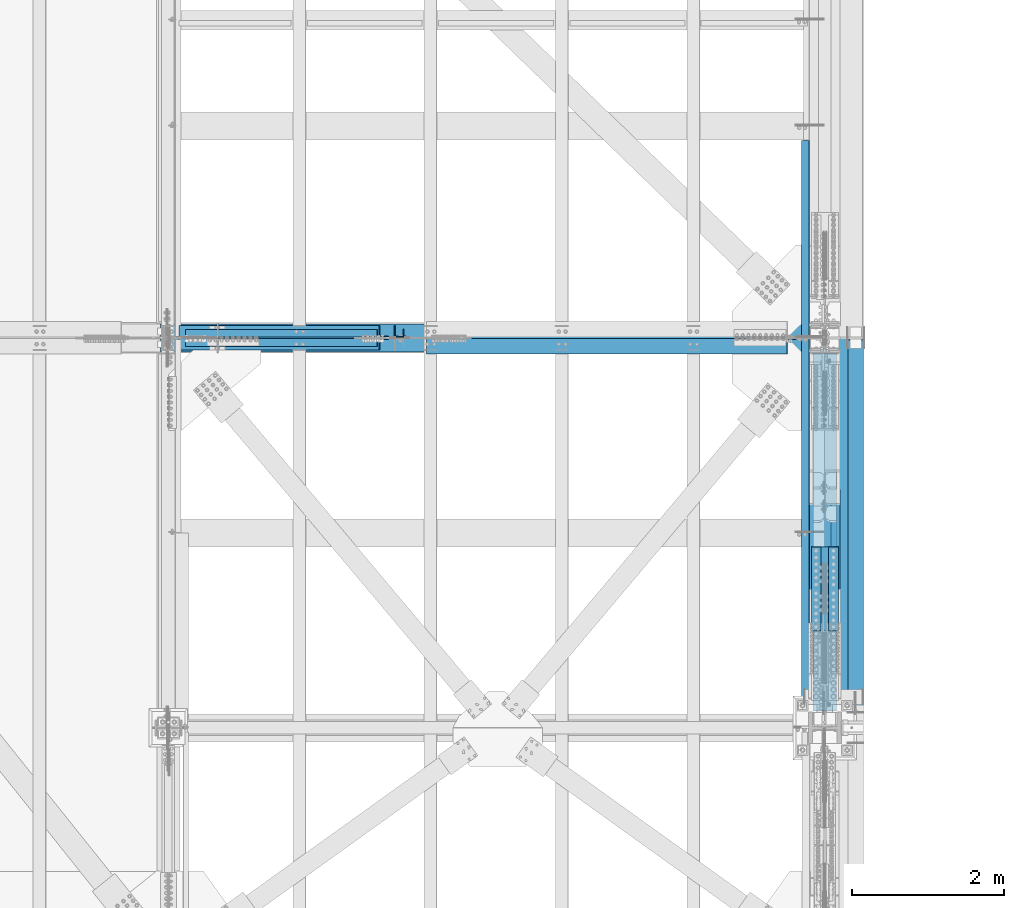
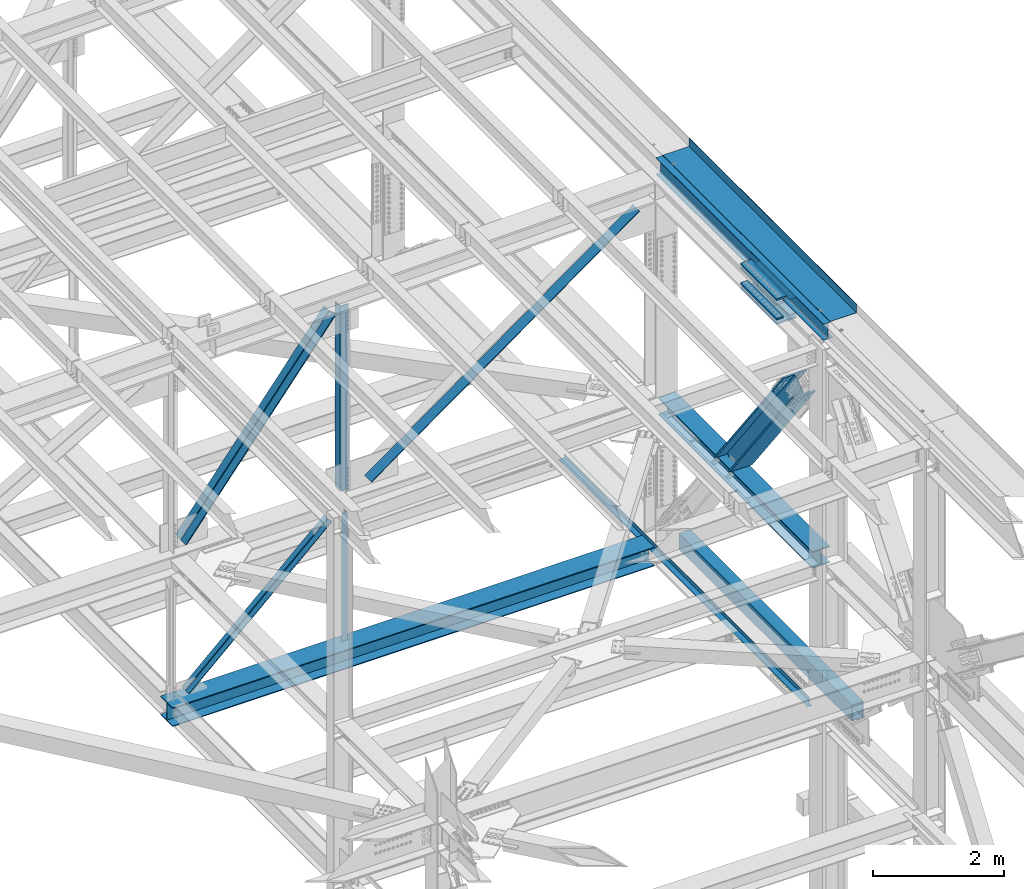
# One storey, part 1959 of 3843: 14 beams, 6 members, 14 elements without a shape of their own.
"""IFC2X3 building model written with IfcOpenShell, lengths in millimetres."""

from ifc_helpers import new_model, si_unit, frame, origin_with_axes, place, context, subcontext, project, spatial, faceted_brep, material, type_object, element, aggregate, save


model = new_model("IFC2X3")

# Units and contexts
model_context = context("Model", 3, precision=1e-05, world=origin_with_axes())
body_context = subcontext(model_context, "Body", "Model", "MODEL_VIEW")
ifc_project = project(units=[si_unit("LENGTHUNIT", "METRE", prefix="MILLI"), si_unit("AREAUNIT", "SQUARE_METRE"), si_unit("VOLUMEUNIT", "CUBIC_METRE"), si_unit("MASSUNIT", "GRAM", prefix="KILO"), si_unit("TIMEUNIT", "SECOND"), si_unit("PLANEANGLEUNIT", "RADIAN"), si_unit("SOLIDANGLEUNIT", "STERADIAN"), si_unit("THERMODYNAMICTEMPERATUREUNIT", "DEGREE_CELSIUS"), si_unit("LUMINOUSINTENSITYUNIT", "LUMEN")], contexts=[model_context])

# Site, building, storey
site_placement = place(None, origin_with_axes())
site = spatial("IfcSite", under=ifc_project, at=site_placement, CompositionType="ELEMENT")
building_placement = place(site_placement, origin_with_axes())
building = spatial("IfcBuilding", under=site, at=building_placement, Name="Undefined", CompositionType="ELEMENT")
storey_placement = place(building_placement, origin_with_axes())
storey = spatial("IfcBuildingStorey", under=building, at=storey_placement, Name="Undefined", CompositionType="ELEMENT", Elevation=0.0)

# Assembly, beam
assembly_1_placement = place(storey_placement, origin_with_axes())
assembly_1 = element("IfcElementAssembly", 1, at=assembly_1_placement, inside=storey, Name="ANGLE", AssemblyPlace="NOTDEFINED", PredefinedType="RIGID_FRAME")
ifc_material_1 = material(Name="STEEL/A572-50")
beam_type_1 = type_object("IfcBeamType", Name="L4X4X3/8", PredefinedType="NOTDEFINED")
beam_1_placement = place(assembly_1_placement, frame((80060.7999999843, 33905.825, 42267.5451161641), z_axis=(-1.0, 0.0, 0.0), x_axis=(0.0, 0.0, -1.0)))
beam_1 = element("IfcBeam", 2, at=beam_1_placement, type_object=beam_type_1, material=ifc_material_1, Name="ANGLE", ObjectType="L4X4X3/8", context=body_context, shape_type="Brep", body=[
    faceted_brep([(209.49954484457, 50.8000000000029, -50.8000000000029), (209.49954484457, 50.8000000000029, 50.8000000000029), (2609.48678539136, 50.8000000000029, 50.8000000000029), (2609.48678539136, 50.8000000000029, -50.8000000000029), (209.49954484457, 41.2750000000015, 50.8000000000029), (2609.48678539136, 41.2750000000015, 50.8000000000029), (209.49954484457, 41.2750000000015, -41.2749999999942), (2609.48678539136, 41.2750000000015, -41.2749999999942), (209.49954484457, -50.8000000000029, -41.2749999999942), (2609.48678539136, -50.8000000000029, -41.2749999999942), (209.49954484457, -50.8000000000029, -50.8000000000029), (2609.48678539136, -50.8000000000029, -50.8000000000029)], [[[0, 1, 2, 3]], [[1, 4, 5, 2]], [[4, 6, 7, 5]], [[6, 8, 9, 7]], [[8, 10, 11, 9]], [[10, 0, 3, 11]], [[5, 7, 9, 11, 3, 2]], [[10, 8, 6, 4, 1, 0]]]),
])
aggregate(assembly_1, [beam_1])

assembly_2_placement = place(storey_placement, origin_with_axes())
assembly_2 = element("IfcElementAssembly", 3, at=assembly_2_placement, inside=storey, Name="BEAM", AssemblyPlace="NOTDEFINED", PredefinedType="RIGID_FRAME")
ifc_material_2 = material(Name="STEEL/A992")
beam_type_2 = type_object("IfcBeamType", Name="W12X26", PredefinedType="NOTDEFINED")
beam_2_placement = place(assembly_2_placement, frame((85648.8000000006, 28714.7, 46612.1749999998), z_axis=(0.0, 0.0, 1.0), x_axis=(0.0, 1.0, 0.0)))
beam_2 = element("IfcBeam", 4, at=beam_2_placement, type_object=beam_type_2, material=ifc_material_2, Name="BEAM", ObjectType="W12X26", context=body_context, shape_type="Brep", body=[
    faceted_brep([(1250.95, -3.17500000000291, -146.050000000003), (1250.95, -82.5500000000029, -146.050000000003), (1250.95, -82.5500000000029, -155.574999999997), (1250.95, 82.5500000000029, -155.574999999997), (1250.95, 82.5500000000029, -146.050000000003), (1250.95, 3.17500000000291, -146.050000000003), (1250.95000000001, 3.17500000000291, -92.0749999997934), (1250.95000000001, -3.17500000000291, -92.0749999997934), (2406.65000000001, -3.17500000000291, -92.0749999997934), (2406.65000000001, 3.17500000000291, -92.0749999997934), (2406.65000000001, 3.17500000000291, -146.050000000003), (2406.65000000001, 82.5500000000029, -146.050000000003), (2406.65000000001, 82.5500000000029, -155.574999999997), (2406.65000000001, -82.5500000000029, -155.574999999997), (2406.65000000001, -82.5500000000029, -146.050000000003), (2406.65000000001, -3.17500000000291, -146.050000000003), (0.0, -82.5500000000029, 155.574999999997), (0.0, -82.5500000000029, 146.050000000003), (5130.8, -82.5500000000029, 146.050000000003), (5130.8, -82.5500000000029, 155.574999999997), (0.0, 82.5500000000029, 155.574999999997), (5130.8, 82.5500000000029, 155.574999999997), (0.0, 82.5500000000029, 146.050000000003), (5130.8, 82.5500000000029, 146.050000000003), (0.0, 3.17500000000291, 146.050000000003), (5130.8, 3.17500000000291, 146.050000000003), (0.0, -82.5500000000029, -155.574999999997), (0.0, -82.5500000000029, -146.050000000003), (0.0, -3.17500000000291, -146.050000000003), (0.0, -3.17500000000291, 146.050000000003), (0.0, 3.17500000000291, -146.050000000003), (0.0, 82.5500000000029, -146.050000000003), (0.0, 82.5500000000029, -155.574999999997), (5130.8, -3.17500000000291, 146.050000000003), (5130.8, 3.17500000000291, -146.050000000003), (5130.8, -3.17500000000291, -146.050000000003), (5130.8, -82.5500000000029, -146.050000000003), (5130.8, -82.5500000000029, -155.574999999997), (5130.8, 82.5500000000029, -155.574999999997), (5130.8, 82.5500000000029, -146.050000000003)], [[[0, 1, 2, 3, 4, 5, 6, 7]], [[8, 9, 10, 11, 12, 13, 14, 15]], [[7, 6, 9, 8]], [[16, 17, 18, 19]], [[20, 16, 19, 21]], [[22, 20, 21, 23]], [[24, 22, 23, 25]], [[26, 27, 28, 29, 17, 16, 20, 22, 24, 30, 31, 32]], [[17, 29, 33, 18]], [[34, 25, 23, 21, 19, 18, 33, 35, 36, 37, 38, 39]], [[36, 35, 15, 14]], [[37, 36, 14, 13]], [[38, 37, 13, 12]], [[39, 38, 12, 11]], [[34, 39, 11, 10]], [[5, 30, 24, 25, 34, 10, 9, 6]], [[31, 30, 5, 4]], [[32, 31, 4, 3]], [[26, 32, 3, 2]], [[27, 26, 2, 1]], [[28, 27, 1, 0]], [[35, 33, 29, 28, 0, 7, 8, 15]]]),
])

# Assembly, member
assembly_3_placement = place(storey_placement, origin_with_axes())
assembly_3 = element("IfcElementAssembly", 5, at=assembly_3_placement, inside=storey, Name="ANGLE", AssemblyPlace="NOTDEFINED", PredefinedType="RIGID_FRAME")
member_type_1 = type_object("IfcMemberType", Name="L4X4X3/8", PredefinedType="NOTDEFINED")
member_1_placement = place(assembly_3_placement, frame((80060.7999999843, 33905.825, 42267.5451161641), z_axis=(0.0, 1.0, 0.0), x_axis=(-0.733899008140415, 0.0, -0.679258600129962)))
member_1 = element("IfcMember", 6, at=member_1_placement, type_object=member_type_1, material=ifc_material_1, Name="ANGLE", ObjectType="L4X4X3/8", context=body_context, shape_type="Brep", body=[
    faceted_brep([(363.598779794396, 50.7999999975509, -50.8000000000029), (363.598779794396, 50.7999999975509, 50.8000000000029), (3797.94778411629, 50.7999999761196, 50.8000000000029), (3797.94778411629, 50.7999999761196, -50.8000000000029), (363.598779794484, 41.2749999975786, 50.8000000000029), (3797.94778411639, 41.2749999761545, 50.8000000000029), (363.598779794484, 41.2749999975786, -41.2750000000015), (3797.94778411639, 41.2749999761545, -41.2750000000015), (363.598779795444, -50.8000000021093, -41.2750000000015), (3797.94778411734, -50.8000000235443, -41.2750000000015), (363.598779795444, -50.8000000021093, -50.8000000000029), (3797.94778411734, -50.8000000235443, -50.8000000000029)], [[[0, 1, 2, 3]], [[1, 4, 5, 2]], [[4, 6, 7, 5]], [[6, 8, 9, 7]], [[8, 10, 11, 9]], [[10, 0, 3, 11]], [[5, 7, 9, 11, 3, 2]], [[10, 8, 6, 4, 1, 0]]]),
])
aggregate(assembly_3, [member_1])

assembly_4_placement = place(storey_placement, origin_with_axes())
assembly_4 = element("IfcElementAssembly", 7, at=assembly_4_placement, inside=storey, Name="ANGLE", AssemblyPlace="NOTDEFINED", PredefinedType="RIGID_FRAME")
member_2_placement = place(assembly_4_placement, frame((77012.8000000054, 33785.175, 39446.4754738793), z_axis=(0.0, -1.0, 0.0), x_axis=(0.733899008140419, 0.0, 0.679258600129958)))
member_2 = element("IfcMember", 8, at=member_2_placement, type_object=member_type_1, material=ifc_material_1, Name="ANGLE", ObjectType="L4X4X3/8", context=body_context, shape_type="Brep", body=[
    faceted_brep([(355.212209667981, 50.8000000020438, -50.8000000000029), (355.212209667981, 50.8000000020438, 50.8000000000029), (3789.56121398989, 50.8000000234751, 50.8000000000029), (3789.56121398989, 50.8000000234751, -50.8000000000029), (355.212209667894, 41.2750000020751, 50.8000000000029), (3789.5612139898, 41.2750000235028, 50.8000000000029), (355.212209667894, 41.2750000020751, -41.2750000000015), (3789.5612139898, 41.2750000235028, -41.2750000000015), (355.212209666948, -50.7999999976091, -41.2750000000015), (3789.56121398884, -50.7999999761814, -41.2750000000015), (355.212209666948, -50.7999999976091, -50.8000000000029), (3789.56121398884, -50.7999999761814, -50.8000000000029)], [[[0, 1, 2, 3]], [[1, 4, 5, 2]], [[4, 6, 7, 5]], [[6, 8, 9, 7]], [[8, 10, 11, 9]], [[10, 0, 3, 11]], [[5, 7, 9, 11, 3, 2]], [[10, 8, 6, 4, 1, 0]]]),
])
aggregate(assembly_4, [member_2])

# Assembly, beam
assembly_5_placement = place(storey_placement, origin_with_axes())
assembly_5 = element("IfcElementAssembly", 9, at=assembly_5_placement, inside=storey, Name="BEAM", AssemblyPlace="NOTDEFINED", PredefinedType="RIGID_FRAME")
ifc_material_3 = material()
beam_type_3 = type_object("IfcBeamType", Name="HSS12X8X3/8", PredefinedType="NOTDEFINED")
beam_3_placement = place(assembly_5_placement, frame((86055.2000000001, 33820.1000003927, 39477.9500003874), z_axis=(0.0, 0.0, 1.0), x_axis=(0.0, -1.0, 0.0)))
beam_3 = element("IfcBeam", 10, at=beam_3_placement, type_object=beam_type_3, material=ifc_material_3, Name="BEAM", ObjectType="HSS12X8X3/8", context=body_context, shape_type="Brep", body=[
    faceted_brep([(0.0, 92.0749999999971, -142.875), (0.0, -92.0749999999971, -142.875), (5302.2500003815, -92.0749999999971, -142.875), (5302.2500003815, 92.0749999999971, -142.875), (0.0, -92.0749999999971, 142.875), (5302.2500003815, -92.0749999999971, 142.875), (0.0, 92.0749999999971, 142.875), (5302.2500003815, 92.0749999999971, 142.875), (0.0, 101.600000000006, -152.400000000001), (0.0, 101.600000000006, 152.400000000001), (5302.2500003815, 101.600000000006, 152.400000000001), (5302.2500003815, 101.600000000006, -152.400000000001), (0.0, -101.600000000006, 152.400000000001), (5302.2500003815, -101.600000000006, 152.400000000001), (0.0, -101.600000000006, -152.400000000001), (5302.2500003815, -101.600000000006, -152.400000000001)], [[[0, 1, 2, 3]], [[1, 4, 5, 2]], [[4, 6, 7, 5]], [[6, 0, 3, 7]], [[8, 9, 10, 11]], [[9, 12, 13, 10]], [[12, 14, 15, 13]], [[14, 8, 11, 15]], [[13, 15, 11, 10], [5, 7, 3, 2]], [[14, 12, 9, 8], [6, 4, 1, 0]]]),
])
aggregate(assembly_5, [beam_3])

# Assembly, beams
assembly_6_placement = place(storey_placement, origin_with_axes())
assembly_6 = element("IfcElementAssembly", 11, at=assembly_6_placement, inside=storey, Name="COLUMN", AssemblyPlace="NOTDEFINED", PredefinedType="RIGID_FRAME")
beam_type_4 = type_object("IfcBeamType", PredefinedType="NOTDEFINED")
beam_4_placement = place(assembly_6_placement, frame((85534.5, 29991.3576152824, 46399.3561913885), z_axis=(1.0, 0.0, 0.0), x_axis=(0.0, 0.999988763159946, 0.00474062800075239)))
beam_4 = element("IfcBeam", 12, at=beam_4_placement, type_object=beam_type_4, material=ifc_material_1, Name="PLATE", context=body_context, shape_type="Brep", body=[
    faceted_brep([(8.73114913702011e-11, 15.8750000000073, -63.5), (8.73114913702011e-11, 15.8750000000073, 63.5), (1104.89999997285, 15.8750000015862, 63.5), (1104.89999997285, 15.8750000015862, -63.5), (-1.01863406598568e-10, -15.8750000000146, 63.5), (1104.89999997268, -15.8749999984284, 63.5), (-1.01863406598568e-10, -15.8750000000146, -63.5), (1104.89999997268, -15.8749999984284, -63.5)], [[[0, 1, 2, 3]], [[1, 4, 5, 2]], [[4, 6, 7, 5]], [[6, 0, 3, 7]], [[5, 7, 3, 2]], [[6, 4, 1, 0]]]),
])
beam_5_placement = place(assembly_6_placement, frame((85534.5, 29992.7270522729, 46110.4869377967), z_axis=(1.0, 0.0, 0.0), x_axis=(0.0, 0.999988763159946, 0.00474062800075239)))
beam_5 = element("IfcBeam", 13, at=beam_5_placement, type_object=beam_type_4, material=ifc_material_1, Name="PLATE", context=body_context, shape_type="Brep", body=[
    faceted_brep([(8.73114913702011e-11, 15.8750000000073, -63.5), (8.73114913702011e-11, 15.8750000000073, 63.5), (1104.89999997285, 15.8750000015862, 63.5), (1104.89999997285, 15.8750000015862, -63.5), (-1.01863406598568e-10, -15.8750000000146, 63.5), (1104.89999997268, -15.8749999984284, 63.5), (-1.01863406598568e-10, -15.8750000000146, -63.5), (1104.89999997268, -15.8749999984284, -63.5)], [[[0, 1, 2, 3]], [[1, 4, 5, 2]], [[4, 6, 7, 5]], [[6, 0, 3, 7]], [[5, 7, 3, 2]], [[6, 4, 1, 0]]]),
])
beam_6_placement = place(assembly_6_placement, frame((85763.1, 29991.3576152824, 46399.3561913885), z_axis=(1.0, 0.0, 0.0), x_axis=(0.0, 0.999988763159946, 0.00474062800075239)))
beam_6 = element("IfcBeam", 14, at=beam_6_placement, type_object=beam_type_4, material=ifc_material_1, Name="PLATE", context=body_context, shape_type="Brep", body=[
    faceted_brep([(8.73114913702011e-11, 15.8750000000073, -63.5), (8.73114913702011e-11, 15.8750000000073, 63.5), (1104.89999997285, 15.8750000015862, 63.5), (1104.89999997285, 15.8750000015862, -63.5), (-1.01863406598568e-10, -15.8750000000146, 63.5), (1104.89999997268, -15.8749999984284, 63.5), (-1.01863406598568e-10, -15.8750000000146, -63.5), (1104.89999997268, -15.8749999984284, -63.5)], [[[0, 1, 2, 3]], [[1, 4, 5, 2]], [[4, 6, 7, 5]], [[6, 0, 3, 7]], [[5, 7, 3, 2]], [[6, 4, 1, 0]]]),
])
beam_7_placement = place(assembly_6_placement, frame((85763.1, 29992.7270522729, 46110.4869377967), z_axis=(1.0, 0.0, 0.0), x_axis=(0.0, 0.999988763159946, 0.00474062800075239)))
beam_7 = element("IfcBeam", 15, at=beam_7_placement, type_object=beam_type_4, material=ifc_material_1, Name="PLATE", context=body_context, shape_type="Brep", body=[
    faceted_brep([(8.73114913702011e-11, 15.8750000000073, -63.5), (8.73114913702011e-11, 15.8750000000073, 63.5), (1104.89999997285, 15.8750000015862, 63.5), (1104.89999997285, 15.8750000015862, -63.5), (-1.01863406598568e-10, -15.8750000000146, 63.5), (1104.89999997268, -15.8749999984284, 63.5), (-1.01863406598568e-10, -15.8750000000146, -63.5), (1104.89999997268, -15.8749999984284, -63.5)], [[[0, 1, 2, 3]], [[1, 4, 5, 2]], [[4, 6, 7, 5]], [[6, 0, 3, 7]], [[5, 7, 3, 2]], [[6, 4, 1, 0]]]),
])
beam_type_5 = type_object("IfcBeamType", PredefinedType="NOTDEFINED")
beam_8_placement = place(assembly_6_placement, frame((85648.8, 31095.8685360715, 46484.0475946934), z_axis=(1.0, 0.0, 0.0), x_axis=(0.0, -0.999988763159946, -0.00474062800075236)))
beam_8 = element("IfcBeam", 16, at=beam_8_placement, type_object=beam_type_5, material=ifc_material_1, Name="PLATE", context=body_context, shape_type="Brep", body=[
    faceted_brep([(1.45519152283669e-11, 15.8750000000218, -177.800000000003), (1.45519152283669e-11, 15.8750000000218, 177.800000000003), (1104.89999996551, 15.8749999977663, 177.800000000003), (1104.89999996551, 15.8749999977663, -177.800000000003), (-4.36557456851006e-11, -15.8750000000146, 177.800000000003), (1104.89999996545, -15.8750000022774, 177.800000000003), (-4.36557456851006e-11, -15.8750000000146, -177.800000000003), (1104.89999996545, -15.8750000022774, -177.800000000003)], [[[0, 1, 2, 3]], [[1, 4, 5, 2]], [[4, 6, 7, 5]], [[6, 0, 3, 7]], [[5, 7, 3, 2]], [[6, 4, 1, 0]]]),
])
beam_9_placement = place(assembly_6_placement, frame((85648.8, 31097.9920680714, 46036.3518196834), z_axis=(1.0, 0.0, 0.0), x_axis=(0.0, -0.999988763159946, -0.00474062800075236)))
beam_9 = element("IfcBeam", 17, at=beam_9_placement, type_object=beam_type_5, material=ifc_material_1, Name="PLATE", context=body_context, shape_type="Brep", body=[
    faceted_brep([(1.45519152283669e-11, 15.8750000000218, -177.800000000003), (1.45519152283669e-11, 15.8750000000218, 177.800000000003), (1104.89999996551, 15.8749999977663, 177.800000000003), (1104.89999996551, 15.8749999977663, -177.800000000003), (-4.36557456851006e-11, -15.8750000000146, 177.800000000003), (1104.89999996545, -15.8750000022774, 177.800000000003), (-4.36557456851006e-11, -15.8750000000146, -177.800000000003), (1104.89999996545, -15.8750000022774, -177.800000000003)], [[[0, 1, 2, 3]], [[1, 4, 5, 2]], [[4, 6, 7, 5]], [[6, 0, 3, 7]], [[5, 7, 3, 2]], [[6, 4, 1, 0]]]),
])
aggregate(assembly_6, [beam_4, beam_5, beam_6, beam_7, beam_8, beam_9])

# Assembly, beam
assembly_7_placement = place(storey_placement, origin_with_axes())
assembly_7 = element("IfcElementAssembly", 18, at=assembly_7_placement, inside=storey, Name="BENT_PLATE", AssemblyPlace="NOTDEFINED", PredefinedType="RIGID_FRAME")
ifc_material_4 = material(Name="STEEL/A36")
beam_type_6 = type_object("IfcBeamType", PredefinedType="NOTDEFINED")
beam_10_placement = place(assembly_7_placement, frame((85343.9999999994, 32632.65, 39627.1749999995), z_axis=(0.0, 1.0, 0.0), x_axis=(1.0, 0.0, 0.0)))
beam_10 = element("IfcBeam", 19, at=beam_10_placement, type_object=beam_type_6, material=ifc_material_4, Name="BENT_PLATE", context=body_context, shape_type="Brep", body=[
    faceted_brep([(74.6125000006432, -3.17500000000291, -3810.0), (74.6125000006432, 3.17500000000291, -3810.0), (74.6125000006723, 3.17500000000291, -3698.87499999997), (74.6125000006723, -3.17500000000291, -3698.87499999997), (101.600000000573, -73.0249999994339, -3698.87499999997), (95.2500000006257, -73.0249999994485, -3698.87499999997), (95.250000000553, -3.17500000000291, -3698.87499999997), (101.600000000544, 3.17500000000291, -3698.87499999997), (0.0, -3.17500000000291, -3810.0), (0.0, -3.17500000000291, 3810.0), (0.0, 3.17500000000291, 3810.0), (0.0, 3.17500000000291, -3810.0), (101.600000000544, 3.17500000000291, 3810.0), (95.250000000553, -3.17500000000291, 3810.0), (95.2500000006257, -73.0249999994485, 3810.0), (101.600000000632, -73.0249999994339, 3810.0)], [[[0, 1, 2, 3]], [[4, 5, 6, 3, 2, 7]], [[8, 9, 10, 11]], [[12, 10, 9, 13, 14, 15]], [[12, 15, 4, 7]], [[1, 11, 10, 12, 7, 2]], [[8, 11, 1, 0]], [[13, 9, 8, 0, 3, 6]], [[14, 13, 6, 5]], [[15, 14, 5, 4]]]),
])
aggregate(assembly_7, [beam_10])

# Assembly, member
assembly_8_placement = place(storey_placement, origin_with_axes())
assembly_8 = element("IfcElementAssembly", 20, at=assembly_8_placement, inside=storey, Name="V. BRACE", AssemblyPlace="NOTDEFINED", PredefinedType="RIGID_FRAME")
member_type_2 = type_object("IfcMemberType", Name="W14X159", PredefinedType="NOTDEFINED")
member_3_placement = place(assembly_8_placement, frame((85648.8, 31746.3281385521, 42261.0815843261), z_axis=(0.0, 0.796057772587748, 0.60522063968658), x_axis=(0.0, -0.605220451019698, 0.796057916025909)))
member_3 = element("IfcMember", 21, at=member_3_placement, type_object=member_type_2, material=ifc_material_2, Name="V. BRACE", ObjectType="W14X159", context=body_context, shape_type="Brep", body=[
    faceted_brep([(345.478452066916, -198.4375, -160.337419722062), (345.478452066916, -9.52499999999418, -160.337499998881), (345.478452066916, 9.52499999999418, -160.337499998881), (345.478452066916, 198.4375, -160.337499998881), (345.478519651093, 198.4375, -190.499999998814), (345.478519651093, -198.4375, -190.499999998814), (131.429996714807, 198.4375, 160.337499999987), (3548.21656815736, 198.4375, 160.337500007838), (3548.21656815736, 9.52499999999418, 160.337500007838), (131.429996714807, 9.52499999999418, 160.337499999987), (81.293946566424, 9.52499999999418, 160.33749999987), (81.293946566424, 198.4375, 160.33749999987), (3548.21656100887, 198.4375, 190.500000007778), (81.0888676904033, 198.4375, 190.499999999811), (3548.21656100887, -198.4375, 190.500000007778), (81.0888676903996, -198.4375, 190.496310283095), (131.429996714807, -198.4375, 160.337499999987), (3548.21656815736, -198.4375, 160.337500007838), (81.293946566424, -198.4375, 160.33749999987), (131.429996714807, -9.52499999999418, 160.337499999987), (3548.21656815736, -9.52499999999418, 160.337500007838), (81.293946566424, -9.52499999999418, 160.33749999987), (148.923278974944, 9.52500025587506, 137.513925582527), (148.923278974944, -9.52499999999418, 137.513925582527), (150.850740387476, 9.52500025623885, 132.637135570214), (150.850740387476, -9.52499999999418, 132.637135570214), (3548.2166441571, 9.52499999999418, -160.337499991518), (373.580607002772, 9.52499999999418, -160.337499998808), (391.136676412632, 9.52500023423636, -137.523244376469), (393.066600247414, 9.52500023346511, -132.65343502882), (392.129756092851, 9.52500023305765, -127.499604208882), (388.609489221162, 9.52500023314497, -123.620510211251), (383.570492164377, 9.52500023368339, -122.189371590313), (317.958505460552, 9.52500052104006, -122.310014887953), (133.823453486635, 9.52500051658717, 122.22160415777), (141.324322246299, 9.52500025890185, 122.184848016848), (146.372621531638, 9.52500025801419, 123.603601923322), (149.904969442199, 9.52500025703921, 127.479257553023), (391.136676412632, -9.52499999999418, -137.523244376469), (373.580607002772, -9.52499999999418, -160.337499998808), (393.066600247414, -9.52499999999418, -132.65343502882), (392.129756092851, -9.52499999999418, -127.499604208882), (388.609489221162, -9.52499999999418, -123.620510211251), (383.570492164377, -9.52499999999418, -122.189371590313), (294.163642078693, -9.52499999999418, -122.353767423498), (109.907394788046, -9.52499999999418, 122.338798852412), (141.324322246299, -9.52499999999418, 122.184848016848), (146.372621531638, -9.52499999999418, 123.603601923322), (149.904969442199, -9.52499999999418, 127.479257553023), (3548.2166441571, -9.52499999999418, -160.337499991518), (3548.2166441571, -198.4375, -160.337499991518), (3548.21665130559, -198.4375, -190.499999991458), (3548.21665130559, 198.4375, -190.499999991458), (3548.2166441571, 198.4375, -160.337499991518), (373.580607002772, -198.4375, -160.337499998808), (373.580607002772, 198.4375, -160.337499998808)], [[[0, 1, 2, 3, 4, 5]], [[6, 7, 8, 9, 10, 11]], [[12, 7, 6, 11, 13]], [[14, 12, 13, 15]], [[16, 17, 14, 15, 18]], [[19, 20, 17, 16, 18, 21]], [[15, 13, 11, 10, 21, 18]], [[9, 19, 21, 10]], [[19, 9, 22, 23]], [[23, 22, 24, 25]], [[9, 8, 26, 27, 28, 29, 30, 31, 32, 33, 34, 35, 36, 37, 24, 22]], [[38, 28, 27, 39]], [[40, 29, 28, 38]], [[41, 30, 29, 40]], [[42, 31, 30, 41]], [[43, 32, 31, 42]], [[44, 33, 32, 43]], [[33, 44, 45, 34]], [[46, 35, 34, 45]], [[47, 36, 35, 46]], [[48, 37, 36, 47]], [[25, 24, 37, 48]], [[47, 46, 45, 44, 43, 42, 41, 40, 38, 39, 49, 20, 19, 23, 25, 48]], [[26, 8, 7, 12, 14, 17, 20, 49, 50, 51, 52, 53]], [[51, 50, 54, 0, 5]], [[52, 51, 5, 4]], [[55, 53, 52, 4, 3]], [[27, 26, 53, 55, 3, 2]], [[39, 27, 2, 1]], [[54, 50, 49, 39, 1, 0]]]),
])
aggregate(assembly_8, [member_3])

# Assembly, beam
assembly_9_placement = place(storey_placement, origin_with_axes())
assembly_9 = element("IfcElementAssembly", 22, at=assembly_9_placement, inside=storey, Name="BEAM", AssemblyPlace="NOTDEFINED", PredefinedType="RIGID_FRAME")
beam_type_7 = type_object("IfcBeamType", Name="W12X87", PredefinedType="NOTDEFINED")
beam_11_placement = place(assembly_9_placement, frame((85648.8, 28715.4330254979, 42246.5516923756), z_axis=(0.0, -0.0046174830016971, 0.99998933936854), x_axis=(0.0, 0.99998933936854, 0.00461748300169892)))
beam_11 = element("IfcBeam", 23, at=beam_11_placement, type_object=beam_type_7, material=ifc_material_2, Name="BEAM", ObjectType="W12X87", context=body_context, shape_type="Brep", body=[
    faceted_brep([(219.077335431914, -153.987500000003, -138.112500000709), (219.07733543199, -153.987500000003, -158.75000000072), (4930.94901609182, -153.987500000003, -158.750000015425), (4931.04431041309, -153.987500000003, -138.112500015421), (219.077335431914, -6.35000000000582, -138.112500000709), (4931.04431041309, -6.35000000000582, -138.112500015421), (219.077335430913, -6.35000000000582, 138.112499999348), (4932.31978825163, -6.35000000000582, 138.112499984643), (219.077335430913, -153.987500000003, 138.112499999348), (4932.31978825163, -153.987500000003, 138.112499984643), (219.077335430837, -153.987500000003, 158.74999999936), (4932.41508257289, -153.987500000003, 158.749999984648), (219.077335430837, 153.987500000003, 158.74999999936), (4932.41508257289, 153.987500000003, 158.749999984648), (219.077335430913, 153.987500000003, 138.112499999348), (4932.31978825163, 153.987500000003, 138.112499984643), (219.077335430913, 6.35000000000582, 138.112499999348), (4932.31978825163, 6.35000000000582, 138.112499984643), (219.077335431914, 6.35000000000582, -138.112500000709), (4931.04431041309, 6.35000000000582, -138.112500015421), (219.077335431914, 153.987500000003, -138.112500000709), (4931.04431041309, 153.987500000003, -138.112500015421), (219.07733543199, 153.987500000003, -158.75000000072), (4930.94901609182, 153.987500000003, -158.750000015425)], [[[0, 1, 2, 3]], [[4, 0, 3, 5]], [[6, 4, 5, 7]], [[8, 6, 7, 9]], [[10, 8, 9, 11]], [[12, 10, 11, 13]], [[14, 12, 13, 15]], [[16, 14, 15, 17]], [[18, 16, 17, 19]], [[20, 18, 19, 21]], [[1, 0, 4, 6, 8, 10, 12, 14, 16, 18, 20, 22]], [[1, 22, 23, 2]], [[19, 17, 15, 13, 11, 9, 7, 5, 3, 2, 23, 21]], [[22, 20, 21, 23]]]),
])
aggregate(assembly_9, [beam_11])

# Beam
beam_type_8 = type_object("IfcBeamType", PredefinedType="NOTDEFINED")
beam_12_placement = place(assembly_2_placement, frame((85680.5500000006, 31280.1, 46772.5124999998), z_axis=(0.0, -1.0, 0.0), x_axis=(1.0, 0.0, 0.0)))
beam_12 = element("IfcBeam", 24, at=beam_12_placement, type_object=beam_type_8, material=ifc_material_4, Name="BENT_PLATE", context=body_context, shape_type="Brep", body=[
    faceted_brep([(466.724999999977, 4.76249999999709, -2562.22500004766), (469.899998426612, 1.58750004770263, -2565.4), (0.0, 1.58750004770263, -2565.4), (0.0, 4.76249999999709, -2562.22500004766), (466.724999999991, 160.337500000009, -2562.22500004766), (469.899998426627, 160.337500000009, -2565.4), (0.0, 4.76249999999709, 2565.4), (466.724999999977, 4.76249999999709, 2565.4), (0.0, -4.76249999999709, -2565.4), (0.0, -4.76249999999709, 2565.4), (476.249999999971, -4.76249999999709, -2565.4), (476.249999999971, -4.76249999999709, 2565.4), (466.724999999991, 160.337500000009, 2565.4), (476.249999999985, 160.337500000009, 2565.4), (476.249999999985, 160.337500000009, -2565.4)], [[[0, 1, 2, 3]], [[4, 5, 1, 0]], [[6, 7, 0, 3]], [[8, 9, 6, 3, 2]], [[9, 8, 10, 11]], [[7, 12, 4, 0]], [[7, 6, 9, 11, 13, 12]], [[11, 10, 14, 13]], [[5, 14, 10, 8, 2, 1]], [[12, 13, 14, 5, 4]]]),
])

aggregate(assembly_2, [beam_12, beam_2])

# Assembly, member
assembly_10_placement = place(storey_placement, origin_with_axes())
assembly_10 = element("IfcElementAssembly", 25, at=assembly_10_placement, inside=storey, Name="ANGLE", AssemblyPlace="NOTDEFINED", PredefinedType="RIGID_FRAME")
member_type_3 = type_object("IfcMemberType", Name="L8X8X1/2", PredefinedType="NOTDEFINED")
member_4_placement = place(assembly_10_placement, frame((80060.7999999646, 33734.375, 42267.5451161442), z_axis=(0.0, -1.0, 0.0), x_axis=(0.812052522383899, 0.0, 0.583584356275891)))
member_4 = element("IfcMember", 26, at=member_4_placement, type_object=member_type_3, material=ifc_material_1, Name="ANGLE", ObjectType="L8X8X1/2", context=body_context, shape_type="Brep", body=[
    faceted_brep([(500.835137178234, 101.600000001516, -101.599999999999), (500.835137178234, 101.600000001516, 101.599999999999), (6340.54548758878, 101.600000013361, 101.599999999999), (6340.54548758878, 101.600000013361, -101.599999999999), (500.835137178248, 88.9000000014457, 101.599999999999), (6340.5454875888, 88.9000000133055, 101.599999999999), (500.835137178248, 88.9000000014457, -88.9000000000015), (6340.5454875888, 88.9000000133055, -88.9000000000015), (500.835137178554, -101.599999999493, -88.9000000000015), (6340.54548758912, -101.599999987655, -88.9000000000015), (500.835137178554, -101.599999999493, -101.599999999999), (6340.54548758912, -101.599999987655, -101.599999999999)], [[[0, 1, 2, 3]], [[1, 4, 5, 2]], [[4, 6, 7, 5]], [[6, 8, 9, 7]], [[8, 10, 11, 9]], [[10, 0, 3, 11]], [[5, 7, 9, 11, 3, 2]], [[10, 8, 6, 4, 1, 0]]]),
])
aggregate(assembly_10, [member_4])

assembly_11_placement = place(storey_placement, origin_with_axes())
assembly_11 = element("IfcElementAssembly", 27, at=assembly_11_placement, inside=storey, Name="ANGLE", AssemblyPlace="NOTDEFINED", PredefinedType="RIGID_FRAME")
member_type_4 = type_object("IfcMemberType", Name="L6X6X1/2", PredefinedType="NOTDEFINED")
member_5_placement = place(assembly_11_placement, frame((80060.7999999455, 33931.225, 46162.4601715785), z_axis=(0.0, 1.0, 0.0), x_axis=(-0.616139496777934, 0.0, -0.787637048716117)))
member_5 = element("IfcMember", 28, at=member_5_placement, type_object=member_type_4, material=ifc_material_1, Name="ANGLE", ObjectType="L6X6X1/2", context=body_context, shape_type="Brep", body=[
    faceted_brep([(349.411254062987, 76.2000000009793, -76.1999999999971), (349.411254062987, 76.2000000009793, 76.1999999999971), (4621.1144138961, 76.2000000089465, 76.1999999999971), (4621.1144138961, 76.2000000089465, -76.1999999999971), (349.411254062914, 63.5000000009095, 76.1999999999971), (4621.11441389604, 63.5000000088767, 76.1999999999971), (349.411254062914, 63.5000000009095, -63.5), (4621.11441389604, 63.5000000088767, -63.5), (349.411254062303, -76.1999999996697, -63.5), (4621.11441389541, -76.1999999917098, -63.5), (349.411254062303, -76.1999999996697, -76.1999999999971), (4621.11441389541, -76.1999999917098, -76.1999999999971)], [[[0, 1, 2, 3]], [[1, 4, 5, 2]], [[4, 6, 7, 5]], [[6, 8, 9, 7]], [[8, 10, 11, 9]], [[10, 0, 3, 11]], [[5, 7, 9, 11, 3, 2]], [[10, 8, 6, 4, 1, 0]]]),
])
aggregate(assembly_11, [member_5])

assembly_12_placement = place(storey_placement, origin_with_axes())
assembly_12 = element("IfcElementAssembly", 29, at=assembly_12_placement, inside=storey, Name="ANGLE", AssemblyPlace="NOTDEFINED", PredefinedType="RIGID_FRAME")
member_6_placement = place(assembly_12_placement, frame((77012.8000000005, 33759.775, 42266.073495852), z_axis=(0.0, -1.0, 0.0), x_axis=(0.616139496777932, 0.0, 0.787637048716118)))
member_6 = element("IfcMember", 30, at=member_6_placement, type_object=member_type_4, material=ifc_material_1, Name="ANGLE", ObjectType="L6X6X1/2", context=body_context, shape_type="Brep", body=[
    faceted_brep([(325.817274160581, 76.1999999997061, -76.1999999999971), (325.817274160581, 76.1999999997061, 76.1999999999971), (4597.5204339937, 76.1999999917316, 76.1999999999971), (4597.5204339937, 76.1999999917316, -76.1999999999971), (325.817274160639, 63.4999999996435, 76.1999999999971), (4597.52043399376, 63.4999999916763, 76.1999999999971), (325.817274160639, 63.4999999996435, -63.5), (4597.52043399376, 63.4999999916763, -63.5), (325.817274161265, -76.200000000943, -63.5), (4597.52043399437, -76.2000000089101, -63.5), (325.817274161265, -76.200000000943, -76.1999999999971), (4597.52043399437, -76.2000000089101, -76.1999999999971)], [[[0, 1, 2, 3]], [[1, 4, 5, 2]], [[4, 6, 7, 5]], [[6, 8, 9, 7]], [[8, 10, 11, 9]], [[10, 0, 3, 11]], [[5, 7, 9, 11, 3, 2]], [[10, 8, 6, 4, 1, 0]]]),
])
aggregate(assembly_12, [member_6])

# Assembly, beam
assembly_13_placement = place(storey_placement, origin_with_axes())
assembly_13 = element("IfcElementAssembly", 31, at=assembly_13_placement, inside=storey, Name="ANGLE", AssemblyPlace="NOTDEFINED", PredefinedType="RIGID_FRAME")
beam_type_9 = type_object("IfcBeamType", Name="L6X6X1/2", PredefinedType="NOTDEFINED")
beam_13_placement = place(assembly_13_placement, frame((80060.7999999455, 33931.225, 46162.4601715785), z_axis=(0.0, 1.0, 0.0), x_axis=(0.0, 0.0, -1.0)))
beam_13 = element("IfcBeam", 32, at=beam_13_placement, type_object=beam_type_9, material=ifc_material_1, Name="ANGLE", ObjectType="L6X6X1/2", context=body_context, shape_type="Brep", body=[
    faceted_brep([(224.210162260992, 76.1999999999971, -76.1999999999971), (224.210162260992, 76.1999999999971, 76.1999999999971), (3685.99790422247, 76.1999999999971, 76.1999999999971), (3685.99790422247, 76.1999999999971, -76.1999999999971), (224.210162260992, 63.5, 76.1999999999971), (3685.99790422247, 63.5, 76.1999999999971), (224.210162260992, 63.5, -63.5), (3685.99790422247, 63.5, -63.5), (224.210162260992, -76.1999999999971, -63.5), (3685.99790422247, -76.1999999999971, -63.5), (224.210162260992, -76.1999999999971, -76.1999999999971), (3685.99790422247, -76.1999999999971, -76.1999999999971)], [[[0, 1, 2, 3]], [[1, 4, 5, 2]], [[4, 6, 7, 5]], [[6, 8, 9, 7]], [[8, 10, 11, 9]], [[10, 0, 3, 11]], [[5, 7, 9, 11, 3, 2]], [[10, 8, 6, 4, 1, 0]]]),
])
aggregate(assembly_13, [beam_13])

assembly_14_placement = place(storey_placement, origin_with_axes())
assembly_14 = element("IfcElementAssembly", 33, at=assembly_14_placement, inside=storey, Name="BEAM", AssemblyPlace="NOTDEFINED", PredefinedType="RIGID_FRAME")
beam_type_10 = type_object("IfcBeamType", Name="W14X90", PredefinedType="NOTDEFINED")
beam_14_placement = place(assembly_14_placement, frame((76910.7190608067, 33845.5, 39446.1993495418), z_axis=(-0.002704930999098, 0.0, 0.999996341667453), x_axis=(0.999996341667453, 0.0, 0.00270493099910052)))
beam_14 = element("IfcBeam", 34, at=beam_14_placement, type_object=beam_type_10, material=ifc_material_2, Name="BEAM", ObjectType="W14X90", context=body_context, shape_type="Brep", body=[
    faceted_brep([(3.34694050252438e-10, 184.149999999994, -177.80000000052), (3.05590219795704e-10, 184.149999999994, -160.337500000467), (8521.77841028498, 184.149999999994, -160.337499983645), (8521.73117525462, 184.149999999994, -177.79999998369), (3.05590219795704e-10, 5.55624999999418, -160.337500000467), (8521.77841028498, 5.55624999999418, -160.337499983645), (-3.20142135024071e-10, 5.55624999999418, 160.33750000046), (8522.64581720637, 5.55624999999418, 160.337500017282), (-3.20142135024071e-10, 184.149999999994, 160.33750000046), (8522.64581720637, 184.149999999994, 160.337500017282), (-3.49245965480804e-10, 184.149999999994, 177.800000000512), (8522.69305223675, 184.149999999994, 177.800000017334), (-3.49245965480804e-10, -184.149999999994, 177.800000000512), (8522.69305223675, -184.149999999994, 177.800000017334), (-3.20142135024071e-10, -184.149999999994, 160.33750000046), (8522.64581720637, -184.149999999994, 160.337500017282), (-3.20142135024071e-10, -5.55624999999418, 160.33750000046), (8522.64581720637, -5.55624999999418, 160.337500017282), (3.05590219795704e-10, -5.55624999999418, -160.337500000467), (8521.77841028498, -5.55624999999418, -160.337499983645), (3.05590219795704e-10, -184.149999999994, -160.337500000467), (8521.77841028498, -184.149999999994, -160.337499983645), (3.34694050252438e-10, -184.149999999994, -177.80000000052), (8521.73117525462, -184.149999999994, -177.79999998369)], [[[0, 1, 2, 3]], [[1, 4, 5, 2]], [[4, 6, 7, 5]], [[6, 8, 9, 7]], [[8, 10, 11, 9]], [[10, 12, 13, 11]], [[12, 14, 15, 13]], [[14, 16, 17, 15]], [[16, 18, 19, 17]], [[18, 20, 21, 19]], [[20, 22, 23, 21]], [[22, 0, 3, 23]], [[5, 7, 9, 11, 13, 15, 17, 19, 21, 23, 3, 2]], [[22, 20, 18, 16, 14, 12, 10, 8, 6, 4, 1, 0]]]),
])
aggregate(assembly_14, [beam_14])

save(model, "model.ifc")
